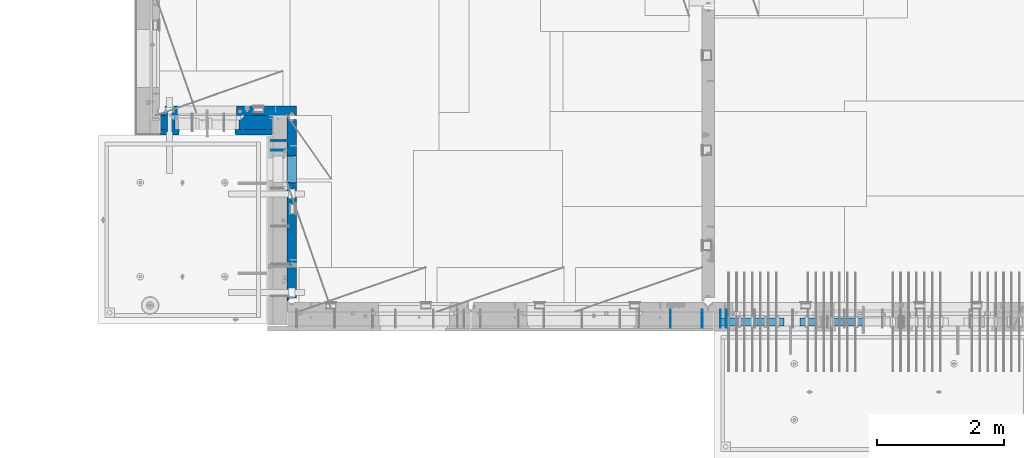
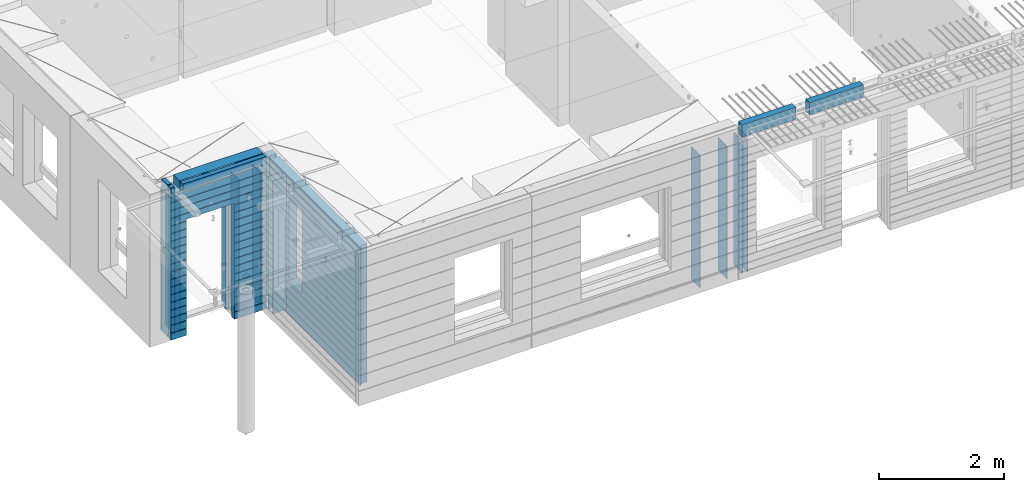
# One storey, part 229 of 350: 16 walls, 7 elements without a shape of their own.
"""IFC2X3 building model written with IfcOpenShell, lengths in millimetres."""

from ifc_helpers import new_model, si_unit, frame, origin_with_axes, place, context, subcontext, project, spatial, faceted_brep, material, type_object, element, aggregate, save


model = new_model("IFC2X3")

# Units and contexts
model_context = context("Model", 3, precision=1e-05, world=origin_with_axes())
body_context = subcontext(model_context, "Body", "Model", "MODEL_VIEW")
ifc_project = project(units=[si_unit("LENGTHUNIT", "METRE", prefix="MILLI"), si_unit("AREAUNIT", "SQUARE_METRE"), si_unit("VOLUMEUNIT", "CUBIC_METRE"), si_unit("MASSUNIT", "GRAM", prefix="KILO"), si_unit("TIMEUNIT", "SECOND"), si_unit("PLANEANGLEUNIT", "RADIAN"), si_unit("SOLIDANGLEUNIT", "STERADIAN"), si_unit("THERMODYNAMICTEMPERATUREUNIT", "DEGREE_CELSIUS"), si_unit("LUMINOUSINTENSITYUNIT", "LUMEN")], contexts=[model_context])

# Site, building, storey
site_placement = place(None, origin_with_axes())
site = spatial("IfcSite", under=ifc_project, at=site_placement, CompositionType="ELEMENT")
building_placement = place(site_placement, origin_with_axes())
building = spatial("IfcBuilding", under=site, at=building_placement, CompositionType="ELEMENT")
storey_placement = place(building_placement, origin_with_axes())
storey = spatial("IfcBuildingStorey", under=building, at=storey_placement, Name="2", CompositionType="ELEMENT", Elevation=0.0)

# Assembly, wall
assembly_1_placement = place(storey_placement, origin_with_axes())
assembly_1 = element("IfcElementAssembly", 1, at=assembly_1_placement, inside=storey, AssemblyPlace="NOTDEFINED", PredefinedType="REINFORCEMENT_UNIT")
ifc_material_1 = material(Name="Undefined")
wall_type_1 = type_object("IfcWallType", PredefinedType="NOTDEFINED")
wall_1_placement = place(assembly_1_placement, frame((16855.0, 7880.0, 86115.0), z_axis=(0.0, 0.0, 1.0), x_axis=(0.0, -1.0, 0.0)))
wall_1 = element("IfcWall", 2, at=wall_1_placement, type_object=wall_type_1, material=ifc_material_1, Name="(PD)", context=body_context, shape_type="Brep", body=[
    faceted_brep([(0.0, 5.0, -1300.0), (0.0, 5.0, 1300.0), (280.0, 5.0, 1300.0), (280.0, 5.0, -1300.0), (0.0, -5.0, 1300.0), (280.0, -5.0, 1300.0), (0.0, -5.0, -1300.0), (280.0, -5.0, -1300.0)], [[[0, 1, 2, 3]], [[1, 4, 5, 2]], [[4, 6, 7, 5]], [[6, 0, 3, 7]], [[5, 7, 3, 2]], [[6, 4, 1, 0]]]),
])

# Assembly, walls
assembly_2_placement = place(storey_placement, origin_with_axes())
assembly_2 = element("IfcElementAssembly", 3, at=assembly_2_placement, inside=storey, AssemblyPlace="NOTDEFINED", PredefinedType="REINFORCEMENT_UNIT")
wall_2_placement = place(assembly_2_placement, frame((16565.0, 7880.0, 86115.0), z_axis=(0.0, 0.0, 1.0), x_axis=(0.0, -1.0, 0.0)))
wall_2 = element("IfcWall", 4, at=wall_2_placement, type_object=wall_type_1, material=ifc_material_1, Name="(PD)", context=body_context, shape_type="Brep", body=[
    faceted_brep([(0.0, 5.0, -1300.0), (0.0, 5.0, 1300.0), (280.0, 5.0, 1300.0), (280.0, 5.0, -1300.0), (0.0, -5.0, 1300.0), (280.0, -5.0, 1300.0), (0.0, -5.0, -1300.0), (280.0, -5.0, -1300.0)], [[[0, 1, 2, 3]], [[1, 4, 5, 2]], [[4, 6, 7, 5]], [[6, 0, 3, 7]], [[5, 7, 3, 2]], [[6, 4, 1, 0]]]),
])
wall_3_placement = place(assembly_2_placement, frame((16065.0, 7880.0, 86115.0), z_axis=(0.0, 0.0, 1.0), x_axis=(0.0, -1.0, 0.0)))
wall_3 = element("IfcWall", 5, at=wall_3_placement, type_object=wall_type_1, material=ifc_material_1, Name="(PD)", context=body_context, shape_type="Brep", body=[
    faceted_brep([(0.0, 5.0, -1300.0), (0.0, 5.0, 1300.0), (280.0, 5.0, 1300.0), (280.0, 5.0, -1300.0), (0.0, -5.0, 1300.0), (280.0, -5.0, 1300.0), (0.0, -5.0, -1300.0), (280.0, -5.0, -1300.0)], [[[0, 1, 2, 3]], [[1, 4, 5, 2]], [[4, 6, 7, 5]], [[6, 0, 3, 7]], [[5, 7, 3, 2]], [[6, 4, 1, 0]]]),
])
aggregate(assembly_2, [wall_2, wall_3])

# Assembly, wall
assembly_3_placement = place(storey_placement, origin_with_axes())
assembly_3 = element("IfcElementAssembly", 6, at=assembly_3_placement, inside=storey, AssemblyPlace="NOTDEFINED", PredefinedType="REINFORCEMENT_UNIT")
wall_4_placement = place(assembly_3_placement, frame((8215.0, 10980.0, 86115.0), z_axis=(0.0, 0.0, 1.0), x_axis=(0.0, -1.0, 0.0)))
wall_4 = element("IfcWall", 7, at=wall_4_placement, type_object=wall_type_1, material=ifc_material_1, Name="(PD)", context=body_context, shape_type="Brep", body=[
    faceted_brep([(0.0, 5.0, -1300.0), (0.0, 5.0, 1300.0), (280.0, 5.0, 1300.0), (280.0, 5.0, -1300.0), (0.0, -5.0, 1300.0), (280.0, -5.0, 1300.0), (0.0, -5.0, -1300.0), (280.0, -5.0, -1300.0)], [[[0, 1, 2, 3]], [[1, 4, 5, 2]], [[4, 6, 7, 5]], [[6, 0, 3, 7]], [[5, 7, 3, 2]], [[6, 4, 1, 0]]]),
])

# Wall
wall_5_placement = place(assembly_1_placement, frame((16945.0, 7880.0, 86115.0), z_axis=(0.0, 0.0, 1.0), x_axis=(0.0, -1.0, 0.0)))
wall_5 = element("IfcWall", 8, at=wall_5_placement, type_object=wall_type_1, material=ifc_material_1, Name="(PD)", context=body_context, shape_type="Brep", body=[
    faceted_brep([(0.0, 5.0, -1300.0), (0.0, 5.0, 1300.0), (280.0, 5.0, 1300.0), (280.0, 5.0, -1300.0), (0.0, -5.0, 1300.0), (280.0, -5.0, 1300.0), (0.0, -5.0, -1300.0), (280.0, -5.0, -1300.0)], [[[0, 1, 2, 3]], [[1, 4, 5, 2]], [[4, 6, 7, 5]], [[6, 0, 3, 7]], [[5, 7, 3, 2]], [[6, 4, 1, 0]]]),
])

aggregate(assembly_1, [wall_1, wall_5])

wall_6_placement = place(assembly_3_placement, frame((8115.0, 10980.0, 86115.0), z_axis=(0.0, 0.0, 1.0), x_axis=(0.0, -1.0, 0.0)))
wall_6 = element("IfcWall", 9, at=wall_6_placement, type_object=wall_type_1, material=ifc_material_1, Name="(PD)", context=body_context, shape_type="Brep", body=[
    faceted_brep([(0.0, 5.0, -1300.0), (0.0, 5.0, 1300.0), (280.0, 5.0, 1300.0), (280.0, 5.0, -1300.0), (0.0, -5.0, 1300.0), (280.0, -5.0, 1300.0), (0.0, -5.0, -1300.0), (280.0, -5.0, -1300.0)], [[[0, 1, 2, 3]], [[1, 4, 5, 2]], [[4, 6, 7, 5]], [[6, 0, 3, 7]], [[5, 7, 3, 2]], [[6, 4, 1, 0]]]),
])

wall_7_placement = place(assembly_3_placement, frame((9315.0, 10980.0, 86115.0), z_axis=(0.0, 0.0, 1.0), x_axis=(0.0, -1.0, 0.0)))
wall_7 = element("IfcWall", 10, at=wall_7_placement, type_object=wall_type_1, material=ifc_material_1, Name="(PD)", context=body_context, shape_type="Brep", body=[
    faceted_brep([(0.0, 5.0, -1300.0), (0.0, 5.0, 1300.0), (280.0, 5.0, 1300.0), (280.0, 5.0, -1300.0), (0.0, -5.0, 1300.0), (280.0, -5.0, 1300.0), (0.0, -5.0, -1300.0), (280.0, -5.0, -1300.0)], [[[0, 1, 2, 3]], [[1, 4, 5, 2]], [[4, 6, 7, 5]], [[6, 0, 3, 7]], [[5, 7, 3, 2]], [[6, 4, 1, 0]]]),
])

wall_8_placement = place(assembly_3_placement, frame((9715.0, 10980.0, 86115.0), z_axis=(0.0, 0.0, 1.0), x_axis=(0.0, -1.0, 0.0)))
wall_8 = element("IfcWall", 11, at=wall_8_placement, type_object=wall_type_1, material=ifc_material_1, Name="(PD)", context=body_context, shape_type="Brep", body=[
    faceted_brep([(0.0, 5.0, -1300.0), (0.0, 5.0, 1300.0), (280.0, 5.0, 1300.0), (280.0, 5.0, -1300.0), (0.0, -5.0, 1300.0), (280.0, -5.0, 1300.0), (0.0, -5.0, -1300.0), (280.0, -5.0, -1300.0)], [[[0, 1, 2, 3]], [[1, 4, 5, 2]], [[4, 6, 7, 5]], [[6, 0, 3, 7]], [[5, 7, 3, 2]], [[6, 4, 1, 0]]]),
])

# Assembly, walls
assembly_4_placement = place(storey_placement, origin_with_axes())
assembly_4 = element("IfcElementAssembly", 12, at=assembly_4_placement, inside=storey, AssemblyPlace="NOTDEFINED", PredefinedType="REINFORCEMENT_UNIT")
wall_9_placement = place(assembly_4_placement, frame((10040.0, 10400.0, 86115.0), z_axis=(0.0, 0.0, 1.0), x_axis=(-1.0, 3.00000001838171e-08, 0.0)))
wall_9 = element("IfcWall", 13, at=wall_9_placement, type_object=wall_type_1, material=ifc_material_1, Name="(PD)", context=body_context, shape_type="Brep", body=[
    faceted_brep([(0.0, 5.0, -1300.0), (0.0, 5.0, 1300.0), (280.0, 5.0, 1300.0), (280.0, 5.0, -1300.0), (0.0, -5.0, 1300.0), (280.0, -5.0, 1300.0), (0.0, -5.0, -1300.0), (280.0, -5.0, -1300.0)], [[[0, 1, 2, 3]], [[1, 4, 5, 2]], [[4, 6, 7, 5]], [[6, 0, 3, 7]], [[5, 7, 3, 2]], [[6, 4, 1, 0]]]),
])
wall_10_placement = place(assembly_4_placement, frame((10040.0, 10550.0, 86115.0), z_axis=(0.0, 0.0, 1.0), x_axis=(-1.0, 3.00000001838171e-08, 0.0)))
wall_10 = element("IfcWall", 14, at=wall_10_placement, type_object=wall_type_1, material=ifc_material_1, Name="(PD)", context=body_context, shape_type="Brep", body=[
    faceted_brep([(0.0, 5.0, -1300.0), (0.0, 5.0, 1300.0), (280.0, 5.0, 1300.0), (280.0, 5.0, -1300.0), (0.0, -5.0, 1300.0), (280.0, -5.0, 1300.0), (0.0, -5.0, -1300.0), (280.0, -5.0, -1300.0)], [[[0, 1, 2, 3]], [[1, 4, 5, 2]], [[4, 6, 7, 5]], [[6, 0, 3, 7]], [[5, 7, 3, 2]], [[6, 4, 1, 0]]]),
])

# Assemblies, walls
assembly_5_placement = place(storey_placement, origin_with_axes())
assembly_5 = element("IfcElementAssembly", 15, at=assembly_5_placement, inside=storey, AssemblyPlace="NOTDEFINED", PredefinedType="REINFORCEMENT_UNIT")
assembly_6_placement = place(assembly_5_placement, origin_with_axes())
assembly_6 = element("IfcElementAssembly", 16, at=assembly_6_placement, Name="Steel Assembly", AssemblyPlace="NOTDEFINED", PredefinedType="NOTDEFINED")
ifc_material_2 = material()
wall_type_2 = type_object("IfcWallType", PredefinedType="NOTDEFINED")
wall_11_placement = place(assembly_6_placement, frame((16859.9998568133, 7690.00021946163, 87590.0), z_axis=(0.0, 0.0, 1.0), x_axis=(1.0, 0.0, 0.0)))
wall_11 = element("IfcWall", 17, at=wall_11_placement, type_object=wall_type_2, material=ifc_material_2, context=body_context, shape_type="Brep", body=[
    faceted_brep([(0.0, 60.0, -120.0), (0.0, 60.0, 120.0), (1000.0, 60.0, 120.0), (1000.0, 60.0, -120.0), (0.0, -60.0, 120.0), (1000.0, -60.0, 120.0), (0.0, -60.0, -120.0), (1000.0, -60.0, -120.0)], [[[0, 1, 2, 3]], [[1, 4, 5, 2]], [[4, 6, 7, 5]], [[6, 0, 3, 7]], [[5, 7, 3, 2]], [[6, 4, 1, 0]]]),
])
aggregate(assembly_6, [wall_11])
assembly_7_placement = place(assembly_5_placement, origin_with_axes())
assembly_7 = element("IfcElementAssembly", 18, at=assembly_7_placement, Name="Steel Assembly", AssemblyPlace="NOTDEFINED", PredefinedType="NOTDEFINED")
aggregate(assembly_5, [assembly_7, assembly_6])
wall_12_placement = place(assembly_7_placement, frame((18109.9998568133, 7690.00021946163, 87590.0), z_axis=(0.0, 0.0, 1.0), x_axis=(1.0, 0.0, 0.0)))
wall_12 = element("IfcWall", 19, at=wall_12_placement, type_object=wall_type_2, material=ifc_material_2, context=body_context, shape_type="Brep", body=[
    faceted_brep([(0.0, 60.0, -120.0), (0.0, 60.0, 120.0), (1000.0, 60.0, 120.0), (1000.0, 60.0, -120.0), (0.0, -60.0, 120.0), (1000.0, -60.0, 120.0), (0.0, -60.0, -120.0), (1000.0, -60.0, -120.0)], [[[0, 1, 2, 3]], [[1, 4, 5, 2]], [[4, 6, 7, 5]], [[6, 0, 3, 7]], [[5, 7, 3, 2]], [[6, 4, 1, 0]]]),
])
aggregate(assembly_7, [wall_12])

# Wall
ifc_material_3 = material(Name="COS5gt")
wall_type_3 = type_object("IfcWallType", PredefinedType="NOTDEFINED")
wall_13_placement = place(assembly_3_placement, frame((9784.0, 10840.0, 86247.5), z_axis=(0.0, 0.0, 1.0), x_axis=(-1.0, 3.00000001838171e-08, 0.0)))
wall_13 = element("IfcWall", 20, at=wall_13_placement, type_object=wall_type_3, material=ifc_material_3, context=body_context, shape_type="Brep", body=[
    faceted_brep([(1699.0, -110.0, 1492.5), (1699.0, 90.0, 1492.5), (1699.0, 90.0, 1442.5), (1699.0, 110.0, 1442.5), (1699.0, 110.0, 1222.5), (1699.0, -110.0, 1222.5), (1549.0, 110.0, 1222.5), (1549.0, -110.0, 1222.5), (1549.0, -110.0, 1492.5), (1549.0, 110.0, 1442.5), (1549.0, 90.0, 1442.5), (1549.0, 90.0, 1492.5), (0.0, -110.0, -1492.5), (0.0, 90.0, -1492.5), (529.001442432404, 90.0, -1492.5), (529.001442432404, -110.0, -1492.5), (0.0, 90.0, -1442.5), (0.0, 110.0, -1442.5), (529.001442432404, 110.0, -1442.5), (529.001442432404, 90.0, -1442.5), (1769.0, 90.0, -1442.5), (1769.0, 90.0, -1492.5), (1539.0014424324, 90.0, -1492.5), (1539.0014424324, 90.0, -1442.5), (1769.0, 110.0, -1442.5), (1539.0014424324, 110.0, -1442.5), (1769.0, 110.0, 1442.5), (1769.0, 90.0, 1442.5), (1769.0, 90.0, 1492.5), (1769.0, -110.0, 1492.5), (1769.0, -110.0, -1492.5), (1539.0014424324, -110.0, -1492.5), (1539.0014424324, -110.0, 847.5), (1539.0014424324, 110.0, 847.5), (529.001442432404, -110.0, 847.5), (529.001442432404, 110.0, 847.5), (0.0, -110.0, 1492.5), (0.0, 90.0, 1492.5), (0.0, 90.0, 1442.5), (0.0, 110.0, 1442.5)], [[[0, 1, 2, 3, 4, 5]], [[5, 4, 6, 7]], [[8, 7, 6, 9, 10, 11]], [[12, 13, 14, 15]], [[16, 17, 18, 19]], [[20, 21, 22, 23]], [[24, 20, 23, 25]], [[26, 27, 28, 29, 30, 21, 20, 24]], [[21, 30, 31, 22]], [[32, 33, 25, 23, 22, 31]], [[34, 35, 33, 32]], [[15, 14, 19, 18, 35, 34]], [[13, 16, 19, 14]], [[13, 12, 36, 37, 38, 39, 17, 16]], [[37, 36, 8, 11]], [[38, 37, 11, 10]], [[39, 38, 10, 9]], [[4, 3, 26, 24, 25, 33, 35, 18, 17, 39, 9, 6]], [[27, 26, 3, 2]], [[28, 27, 2, 1]], [[29, 28, 1, 0]], [[36, 12, 15, 34, 32, 31, 30, 29, 0, 5, 7, 8]]]),
])

ifc_material_4 = material(Name="CONCRETE/C30/37")
wall_type_4 = type_object("IfcWallType", PredefinedType="NOTDEFINED")
wall_14_placement = place(assembly_3_placement, frame((9784.0, 10687.5, 86247.5), z_axis=(0.0, 0.0, 1.0), x_axis=(-1.0, 3.00000001838171e-08, 0.0)))
wall_14 = element("IfcWall", 21, at=wall_14_placement, type_object=wall_type_4, material=ifc_material_4, context=body_context, shape_type="Brep", body=[
    faceted_brep([(1699.0, -42.5, 1492.5), (1699.0, 42.5, 1492.5), (1699.0, 42.5, 1356.99999988925), (1699.0, 32.4999991126988, 1355.00000040044), (1699.0, 32.4999992506928, 1344.99999999921), (1699.0, 42.5, 1342.99999994476), (1699.0, 42.5, 1222.5), (1699.0, -42.5, 1222.5), (1549.0, 42.5, 1222.5), (1549.0, -42.5, 1222.5), (1549.0, -42.5, 1492.5), (1549.0, 42.5, 1342.99999994476), (1549.0, 32.4999992506928, 1344.99999999921), (1549.0, 32.4999991126988, 1355.00000040044), (1549.0, 42.5, 1356.99999988925), (1549.0, 42.5, 1492.5), (1478.99938360887, 42.5, 606.999999889245), (1769.0, 42.5, 606.999999889245), (1769.0, 32.4999991126988, 605.00000040044), (1477.8227168378, 32.4999991126988, 605.00000040044), (1769.0, 32.4999992506928, 594.999999999214), (1477.82271685404, 32.4999992506928, 594.999999999214), (1769.0, 42.5, 592.999999944761), (1478.99938360887, 42.5, 592.999999944761), (1769.0, 42.5, 456.999999889245), (1478.99938360887, 42.5, 456.999999889245), (1769.0, 32.4999991126988, 455.00000040044), (1477.8227168378, 32.4999991126988, 455.00000040044), (1769.0, 32.4999992506928, 444.999999999214), (1477.82271685404, 32.4999992506928, 444.999999999214), (1769.0, 42.5, 442.999999944761), (1478.99938360887, 42.5, 442.999999944761), (1769.0, 42.5, 306.999999889245), (1478.99938360887, 42.5, 306.999999889245), (1769.0, 32.4999991126988, 305.00000040044), (1477.8227168378, 32.4999991126988, 305.00000040044), (1769.0, 32.4999992506928, 294.999999999214), (1477.82271685404, 32.4999992506928, 294.999999999214), (1769.0, 42.5, 292.999999944761), (1478.99938360887, 42.5, 292.999999944761), (1769.0, 42.5, 156.999999889245), (1478.99938360887, 42.5, 156.999999889245), (1769.0, 32.4999991126988, 155.00000040044), (1477.8227168378, 32.4999991126988, 155.00000040044), (1769.0, 32.4999992506928, 144.999999999214), (1477.82271685404, 32.4999992506928, 144.999999999214), (1769.0, 42.5, 142.999999944761), (1478.99938360887, 42.5, 142.999999944761), (1769.0, 42.5, 6.99999988924537), (1478.99938360887, 42.5, 6.99999988924537), (1769.0, 32.4999991126988, 5.0000004004396), (1477.8227168378, 32.4999991126988, 5.0000004004396), (1769.0, 32.4999992506928, -5.0000000007858), (1477.82271685404, 32.4999992506928, -5.0000000007858), (1769.0, 42.5, -7.00000005523907), (1478.99938360887, 42.5, -7.00000005523907), (1769.0, 42.5, -143.000000110755), (1478.99938360887, 42.5, -143.000000110755), (1769.0, 32.4999991126988, -144.99999959956), (1477.8227168378, 32.4999991126988, -144.99999959956), (1769.0, 32.4999992506928, -155.000000000786), (1477.82271685404, 32.4999992506928, -155.000000000786), (1769.0, 42.5, -157.000000055239), (1478.99938360887, 42.5, -157.000000055239), (1769.0, 42.5, -293.000000110755), (1478.99938360887, 42.5, -293.000000110755), (1769.0, 32.4999991126988, -294.99999959956), (1477.8227168378, 32.4999991126988, -294.99999959956), (1769.0, 32.4999992506928, -305.000000000786), (1477.82271685404, 32.4999992506928, -305.000000000786), (1769.0, 42.5, -307.000000055239), (1478.99938360887, 42.5, -307.000000055239), (1769.0, 42.5, -443.000000110755), (1478.99938360887, 42.5, -443.000000110755), (1769.0, 32.4999991126988, -444.99999959956), (1477.8227168378, 32.4999991126988, -444.99999959956), (1769.0, 32.4999992506928, -455.000000000786), (1477.82271685404, 32.4999992506928, -455.000000000786), (1769.0, 42.5, -457.000000055239), (1478.99938360887, 42.5, -457.000000055239), (1769.0, 42.5, -593.000000110755), (1478.99938360887, 42.5, -593.000000110755), (1769.0, 32.4999991126988, -594.99999959956), (1477.8227168378, 32.4999991126988, -594.99999959956), (1769.0, 32.4999992506928, -605.000000000786), (1477.82271685404, 32.4999992506928, -605.000000000786), (1769.0, 42.5, -607.000000055239), (1478.99938360887, 42.5, -607.000000055239), (1769.0, 42.5, -743.000000110755), (1478.99938360887, 42.5, -743.000000110755), (1769.0, 32.4999991126988, -744.99999959956), (1477.8227168378, 32.4999991126988, -744.99999959956), (1769.0, 32.4999992506928, -755.000000000786), (1477.82271685404, 32.4999992506928, -755.000000000786), (1769.0, 42.5, -757.000000055239), (1478.99938360887, 42.5, -757.000000055239), (1769.0, 42.5, -893.000000110755), (1478.99938360887, 42.5, -893.000000110755), (1769.0, 32.4999991126988, -894.99999959956), (1477.8227168378, 32.4999991126988, -894.99999959956), (1769.0, 32.4999992506928, -905.000000000786), (1477.82271685404, 32.4999992506928, -905.000000000786), (1769.0, 42.5, -907.000000055239), (1478.99938360887, 42.5, -907.000000055239), (1769.0, 42.5, -1043.00000011075), (1478.99938360887, 42.5, -1043.00000011075), (1769.0, 32.4999991126988, -1044.99999959956), (1477.8227168378, 32.4999991126988, -1044.99999959956), (1769.0, 32.4999992506928, -1055.00000000079), (1477.82271685404, 32.4999992506928, -1055.00000000079), (1769.0, 42.5, -1057.00000005524), (1478.99938360887, 42.5, -1057.00000005524), (1769.0, 42.5, -1193.00000011075), (1478.99938360887, 42.5, -1193.00000011075), (1769.0, 32.4999991126988, -1194.99999959956), (1477.8227168378, 32.4999991126988, -1194.99999959956), (1769.0, 32.4999992506928, -1205.00000000079), (1477.82271685404, 32.4999992506928, -1205.00000000079), (1769.0, 42.5, -1207.00000005524), (1478.99938360887, 42.5, -1207.00000005524), (1769.0, 42.5, -1343.00000011075), (1478.99938360887, 42.5, -1343.00000011075), (1769.0, 32.4999991126988, -1344.99999959956), (1477.8227168378, 32.4999991126988, -1344.99999959956), (1769.0, 32.4999992506928, -1355.00000000079), (1477.82271685404, 32.4999992506928, -1355.00000000079), (1769.0, 42.5, -1357.00000005524), (1478.99938360887, 42.5, -1357.00000005524), (1769.0, 42.5, -1492.5), (1478.99938360887, 42.5, -1492.5), (1769.0, -42.5, -1492.5), (1468.99771694221, -42.5, -1492.5), (599.001442432404, 42.5, 782.5), (1469.0014424324, 42.5, 782.5), (1478.99938360887, 42.5, 782.5), (1468.99771694221, -42.5, 787.502857142856), (599.001050275541, -42.5, 787.502857142856), (588.999383608874, 42.5, 782.5), (1478.99938360887, 42.5, 742.999999944761), (1468.99771694221, -42.5, 782.5), (1478.99938360887, 42.5, 756.999999889245), (1477.82271683781, 32.4999991126988, 755.00000040044), (1477.82271685404, 32.4999992506928, 744.999999999214), (1769.0, 42.5, 742.999999944761), (1769.0, 32.4999992506928, 744.999999999214), (1769.0, 32.4999991126988, 755.00000040044), (1769.0, 42.5, 756.999999889245), (0.0, 32.4999991127006, 905.00000040044), (1769.0, 32.4999991126988, 905.00000040044), (1769.0, 32.4999992506928, 894.999999999214), (0.0, 32.4999992507037, 894.999999999258), (0.0, 42.5, 906.999999889245), (1769.0, 42.5, 906.999999889245), (0.0, 42.5, 1042.99999994476), (1769.0, 42.5, 1042.99999994476), (0.0, 32.4999992507037, 1044.99999999926), (1769.0, 32.4999992506928, 1044.99999999921), (0.0, 32.4999991127006, 1055.00000040044), (1769.0, 32.4999991126988, 1055.00000040044), (0.0, 42.5, 1056.99999988925), (1769.0, 42.5, 1056.99999988925), (0.0, 42.5, 1192.99999994476), (1769.0, 42.5, 1192.99999994476), (0.0, 32.4999992507037, 1194.99999999926), (1769.0, 32.4999992506928, 1194.99999999921), (0.0, 32.4999991127006, 1205.00000040044), (1769.0, 32.4999991126988, 1205.00000040044), (0.0, 42.5, 1206.99999988925), (1769.0, 42.5, 1206.99999988925), (1769.0, 42.5, 1492.5), (1769.0, -42.5, 1492.5), (1769.0, 42.5, 892.999999944761), (1769.0, 42.5, 1342.99999994476), (1769.0, 32.4999992506928, 1344.99999999921), (1769.0, 32.4999991126988, 1355.00000040044), (1769.0, 42.5, 1356.99999988925), (0.0, 42.5, 892.999999944761), (588.999383608874, 42.5, 756.999999889245), (0.0, 42.5, 756.999999889245), (588.999383608874, 42.5, -1492.5), (0.0, 42.5, -1492.5), (0.0, 42.5, -1357.00000005524), (588.999383608874, 42.5, -1357.00000005524), (0.0, 32.4999992507037, -1355.00000000074), (590.176050363707, 32.4999992506928, -1355.00000000079), (0.0, 32.4999991127006, -1344.99999959956), (590.176050379945, 32.4999991126988, -1344.99999959956), (0.0, 42.5, -1343.00000011075), (588.999383608874, 42.5, -1343.00000011075), (0.0, 42.5, -1207.00000005524), (588.999383608874, 42.5, -1207.00000005524), (0.0, 32.4999992507037, -1205.00000000074), (590.176050363709, 32.4999992506928, -1205.00000000079), (0.0, 32.4999991127006, -1194.99999959956), (590.176050379947, 32.4999991126988, -1194.99999959956), (0.0, 42.5, -1193.00000011075), (588.999383608874, 42.5, -1193.00000011075), (0.0, 42.5, -1057.00000005524), (588.999383608874, 42.5, -1057.00000005524), (0.0, 32.4999992507037, -1055.00000000074), (590.176050363711, 32.4999992506928, -1055.00000000079), (0.0, 32.4999991127006, -1044.99999959956), (590.176050379947, 32.4999991126988, -1044.99999959956), (0.0, 42.5, -1043.00000011075), (588.999383608874, 42.5, -1043.00000011075), (0.0, 42.5, -907.000000055239), (588.999383608874, 42.5, -907.000000055239), (0.0, 32.4999992507037, -905.000000000742), (590.176050363711, 32.4999992506928, -905.000000000786), (0.0, 32.4999991127006, -894.99999959956), (590.176050379947, 32.4999991126988, -894.99999959956), (0.0, 42.5, -893.000000110755), (588.999383608874, 42.5, -893.000000110755), (0.0, 42.5, -757.000000055239), (588.999383608874, 42.5, -757.000000055239), (0.0, 32.4999992507037, -755.000000000742), (590.176050363711, 32.4999992506928, -755.000000000786), (0.0, 32.4999991127006, -744.99999959956), (590.176050379947, 32.4999991126988, -744.99999959956), (0.0, 42.5, -743.000000110755), (588.999383608874, 42.5, -743.000000110755), (0.0, 42.5, -607.000000055239), (588.999383608874, 42.5, -607.000000055239), (3.63797880709171e-12, 32.4999992507037, -605.000000000742), (590.176050363709, 32.4999992506928, -605.000000000786), (3.63797880709171e-12, 32.4999991127006, -594.99999959956), (590.176050379947, 32.4999991126988, -594.99999959956), (0.0, 42.5, -593.000000110755), (588.999383608874, 42.5, -593.000000110755), (0.0, 42.5, -457.000000055239), (588.999383608874, 42.5, -457.000000055239), (0.0, 32.4999992507037, -455.000000000742), (590.176050363711, 32.4999992506928, -455.000000000786), (0.0, 32.4999991127006, -444.99999959956), (590.176050379947, 32.4999991126988, -444.99999959956), (0.0, 42.5, -443.000000110755), (588.999383608874, 42.5, -443.000000110755), (0.0, 42.5, -307.000000055239), (588.999383608874, 42.5, -307.000000055239), (0.0, 32.4999992507037, -305.000000000742), (590.176050363711, 32.4999992506928, -305.000000000786), (0.0, 32.4999991127006, -294.99999959956), (590.176050379947, 32.4999991126988, -294.99999959956), (0.0, 42.5, -293.000000110755), (588.999383608874, 42.5, -293.000000110755), (0.0, 42.5, -157.000000055239), (588.999383608874, 42.5, -157.000000055239), (3.63797880709171e-12, 32.4999992507037, -155.000000000742), (590.176050363707, 32.4999992506928, -155.000000000786), (3.63797880709171e-12, 32.4999991127006, -144.99999959956), (590.176050379945, 32.4999991126988, -144.99999959956), (0.0, 42.5, -143.000000110755), (588.999383608874, 42.5, -143.000000110755), (0.0, 42.5, -7.00000005523907), (588.999383608874, 42.5, -7.00000005523907), (0.0, 32.4999992507037, -5.00000000074215), (590.176050363705, 32.4999992506928, -5.0000000007858), (0.0, 32.4999991127006, 5.0000004004396), (590.176050379941, 32.4999991126988, 5.0000004004396), (0.0, 42.5, 6.99999988924537), (588.999383608874, 42.5, 6.99999988924537), (0.0, 42.5, 142.999999944761), (588.999383608874, 42.5, 142.999999944761), (-3.63797880709171e-12, 32.4999992507037, 144.999999999258), (590.176050363705, 32.4999992506928, 144.999999999214), (-3.63797880709171e-12, 32.4999991127006, 155.00000040044), (590.176050379943, 32.4999991126988, 155.00000040044), (0.0, 42.5, 156.999999889245), (588.999383608874, 42.5, 156.999999889245), (0.0, 42.5, 292.999999944761), (588.999383608874, 42.5, 292.999999944761), (-3.63797880709171e-12, 32.4999992507037, 294.999999999258), (590.176050363703, 32.4999992506928, 294.999999999214), (-3.63797880709171e-12, 32.4999991127006, 305.00000040044), (590.17605037994, 32.4999991126988, 305.00000040044), (0.0, 42.5, 306.999999889245), (588.999383608874, 42.5, 306.999999889245), (0.0, 42.5, 442.999999944761), (588.999383608874, 42.5, 442.999999944761), (0.0, 32.4999992507037, 444.999999999258), (590.176050363702, 32.4999992506928, 444.999999999214), (0.0, 32.4999991127006, 455.00000040044), (590.176050379938, 32.4999991126988, 455.00000040044), (0.0, 42.5, 456.999999889245), (588.999383608874, 42.5, 456.999999889245), (0.0, 42.5, 592.999999944761), (588.999383608874, 42.5, 592.999999944761), (3.63797880709171e-12, 32.4999992507037, 594.999999999258), (590.176050363702, 32.4999992506928, 594.999999999214), (3.63797880709171e-12, 32.4999991127006, 605.00000040044), (590.17605037994, 32.4999991126988, 605.00000040044), (0.0, 42.5, 606.999999889245), (588.999383608874, 42.5, 606.999999889245), (0.0, 42.5, 742.999999944761), (588.999383608874, 42.5, 742.999999944761), (0.0, 32.4999992507037, 744.999999999258), (590.176050363705, 32.4999992506928, 744.999999999214), (0.0, 32.4999991127006, 755.00000040044), (590.176050379943, 32.4999991126988, 755.00000040044), (599.001050275541, -42.5, 782.5), (599.001050275539, -42.5, -1492.5), (0.0, -42.5, -1492.5), (-3.63797880709171e-12, 32.4999992507037, 1344.99999999926), (0.0, 42.5, 1342.99999994476), (0.0, -42.5, 1492.5), (0.0, 42.5, 1492.5), (0.0, 42.5, 1356.99999988925), (-3.63797880709171e-12, 32.4999991127006, 1355.00000040044)], [[[0, 1, 2, 3, 4, 5, 6, 7]], [[7, 6, 8, 9]], [[10, 9, 8, 11, 12, 13, 14, 15]], [[16, 17, 18, 19]], [[19, 18, 20, 21]], [[21, 20, 22, 23]], [[24, 25, 23, 22]], [[25, 24, 26, 27]], [[27, 26, 28, 29]], [[29, 28, 30, 31]], [[32, 33, 31, 30]], [[33, 32, 34, 35]], [[35, 34, 36, 37]], [[37, 36, 38, 39]], [[40, 41, 39, 38]], [[41, 40, 42, 43]], [[43, 42, 44, 45]], [[45, 44, 46, 47]], [[48, 49, 47, 46]], [[49, 48, 50, 51]], [[51, 50, 52, 53]], [[53, 52, 54, 55]], [[56, 57, 55, 54]], [[57, 56, 58, 59]], [[59, 58, 60, 61]], [[61, 60, 62, 63]], [[64, 65, 63, 62]], [[65, 64, 66, 67]], [[67, 66, 68, 69]], [[69, 68, 70, 71]], [[72, 73, 71, 70]], [[73, 72, 74, 75]], [[75, 74, 76, 77]], [[77, 76, 78, 79]], [[80, 81, 79, 78]], [[81, 80, 82, 83]], [[83, 82, 84, 85]], [[85, 84, 86, 87]], [[88, 89, 87, 86]], [[89, 88, 90, 91]], [[91, 90, 92, 93]], [[93, 92, 94, 95]], [[96, 97, 95, 94]], [[97, 96, 98, 99]], [[99, 98, 100, 101]], [[101, 100, 102, 103]], [[104, 105, 103, 102]], [[105, 104, 106, 107]], [[107, 106, 108, 109]], [[109, 108, 110, 111]], [[112, 113, 111, 110]], [[113, 112, 114, 115]], [[115, 114, 116, 117]], [[117, 116, 118, 119]], [[120, 121, 119, 118]], [[121, 120, 122, 123]], [[123, 122, 124, 125]], [[125, 124, 126, 127]], [[128, 129, 127, 126]], [[128, 130, 131, 129]], [[132, 133, 134, 135, 136, 137]], [[138, 16, 19, 21, 23, 25, 27, 29, 31, 33, 35, 37, 39, 41, 43, 45, 47, 49, 51, 53, 55, 57, 59, 61, 63, 65, 67, 69, 71, 73, 75, 77, 79, 81, 83, 85, 87, 89, 91, 93, 95, 97, 99, 101, 103, 105, 107, 109, 111, 113, 115, 117, 119, 121, 123, 125, 127, 129, 131, 139, 135, 134, 140, 141, 142]], [[17, 16, 138, 143]], [[142, 144, 143, 138]], [[141, 145, 144, 142]], [[140, 146, 145, 141]], [[147, 148, 149, 150]], [[151, 152, 148, 147]], [[152, 151, 153, 154]], [[155, 156, 154, 153]], [[157, 158, 156, 155]], [[159, 160, 158, 157]], [[160, 159, 161, 162]], [[163, 164, 162, 161]], [[165, 166, 164, 163]], [[167, 168, 166, 165]], [[169, 170, 130, 128, 126, 124, 122, 120, 118, 116, 114, 112, 110, 108, 106, 104, 102, 100, 98, 96, 94, 92, 90, 88, 86, 84, 82, 80, 78, 76, 74, 72, 70, 68, 66, 64, 62, 60, 58, 56, 54, 52, 50, 48, 46, 44, 42, 40, 38, 36, 34, 32, 30, 28, 26, 24, 22, 20, 18, 17, 143, 144, 145, 146, 171, 149, 148, 152, 154, 156, 158, 160, 162, 164, 166, 168, 172, 173, 174, 175]], [[150, 149, 171, 176]], [[146, 140, 134, 133, 132, 137, 177, 178, 176, 171]], [[179, 180, 181, 182]], [[183, 184, 182, 181]], [[185, 186, 184, 183]], [[187, 188, 186, 185]], [[188, 187, 189, 190]], [[191, 192, 190, 189]], [[193, 194, 192, 191]], [[195, 196, 194, 193]], [[196, 195, 197, 198]], [[199, 200, 198, 197]], [[201, 202, 200, 199]], [[203, 204, 202, 201]], [[204, 203, 205, 206]], [[207, 208, 206, 205]], [[209, 210, 208, 207]], [[211, 212, 210, 209]], [[212, 211, 213, 214]], [[215, 216, 214, 213]], [[217, 218, 216, 215]], [[219, 220, 218, 217]], [[220, 219, 221, 222]], [[223, 224, 222, 221]], [[225, 226, 224, 223]], [[227, 228, 226, 225]], [[228, 227, 229, 230]], [[231, 232, 230, 229]], [[233, 234, 232, 231]], [[235, 236, 234, 233]], [[236, 235, 237, 238]], [[239, 240, 238, 237]], [[241, 242, 240, 239]], [[243, 244, 242, 241]], [[244, 243, 245, 246]], [[247, 248, 246, 245]], [[249, 250, 248, 247]], [[251, 252, 250, 249]], [[252, 251, 253, 254]], [[255, 256, 254, 253]], [[257, 258, 256, 255]], [[259, 260, 258, 257]], [[260, 259, 261, 262]], [[263, 264, 262, 261]], [[265, 266, 264, 263]], [[267, 268, 266, 265]], [[268, 267, 269, 270]], [[271, 272, 270, 269]], [[273, 274, 272, 271]], [[275, 276, 274, 273]], [[276, 275, 277, 278]], [[279, 280, 278, 277]], [[281, 282, 280, 279]], [[283, 284, 282, 281]], [[284, 283, 285, 286]], [[287, 288, 286, 285]], [[289, 290, 288, 287]], [[291, 292, 290, 289]], [[292, 291, 293, 294]], [[295, 296, 294, 293]], [[297, 298, 296, 295]], [[178, 177, 298, 297]], [[137, 136, 299, 300, 179, 182, 184, 186, 188, 190, 192, 194, 196, 198, 200, 202, 204, 206, 208, 210, 212, 214, 216, 218, 220, 222, 224, 226, 228, 230, 232, 234, 236, 238, 240, 242, 244, 246, 248, 250, 252, 254, 256, 258, 260, 262, 264, 266, 268, 270, 272, 274, 276, 278, 280, 282, 284, 286, 288, 290, 292, 294, 296, 298, 177]], [[301, 180, 179, 300]], [[302, 303, 167, 165, 163, 161, 159, 157, 155, 153, 151, 147, 150, 176, 178, 297, 295, 293, 291, 289, 287, 285, 283, 281, 279, 277, 275, 273, 271, 269, 267, 265, 263, 261, 259, 257, 255, 253, 251, 249, 247, 245, 243, 241, 239, 237, 235, 233, 231, 229, 227, 225, 223, 221, 219, 217, 215, 213, 211, 209, 207, 205, 203, 201, 199, 197, 195, 193, 191, 189, 187, 185, 183, 181, 180, 301, 304, 305, 306, 307]], [[305, 304, 10, 15]], [[306, 305, 15, 14]], [[307, 306, 14, 13]], [[302, 307, 13, 12]], [[303, 302, 12, 11]], [[6, 5, 172, 168, 167, 303, 11, 8]], [[173, 172, 5, 4]], [[174, 173, 4, 3]], [[175, 174, 3, 2]], [[169, 175, 2, 1]], [[170, 169, 1, 0]], [[304, 301, 300, 299, 136, 135, 139, 131, 130, 170, 0, 7, 9, 10]]]),
])

ifc_material_5 = material(Name="CONCRETE/C25/30")
wall_type_5 = type_object("IfcWallType", PredefinedType="NOTDEFINED")
wall_15_placement = place(assembly_3_placement, frame((10160.0, 11025.0, 86112.5), z_axis=(0.0, 0.0, 1.0), x_axis=(-1.0, 3.00000001838171e-08, 0.0)))
wall_15 = element("IfcWall", 22, at=wall_15_placement, type_object=wall_type_5, material=ifc_material_5, context=body_context, shape_type="Brep", body=[
    faceted_brep([(47.9999996848892, 54.9999994175323, 1357.5), (47.9999996848892, 54.9999994175323, -1357.5), (34.999999998452, 55.0000022791301, -1357.5), (34.999999998452, 55.0000022791301, 1357.5), (24.999999998452, 75.0000022791301, 1357.5), (24.999999998452, 75.0, -1357.5), (124.999999998452, 75.0, 1357.5), (124.999999998452, 75.0, -1357.5), (114.999999998452, 55.0000022791301, -1357.5), (114.999999998452, 55.0000022791301, 1357.5), (101.99999958942, 54.999999390373, 1357.5), (101.99999958942, 54.999999390373, -1357.5), (945.001442432404, -75.0, -1357.5), (949.055496486459, 75.0, -1357.5), (949.055496486457, 75.0, 948.445945945947), (945.001442432404, -75.0, 952.5), (0.0, -75.0, -1357.5), (0.0, 75.0, -1357.5), (2145.0, 75.0, 1357.5), (2145.0, 75.0, -1357.5), (1870.94738837835, 75.0, -1357.5), (1870.94738837835, 75.0, 948.445945945947), (2145.0, 45.0, 1357.5), (2145.0, 45.0, -1357.5), (2074.9999995581, 32.0, 1357.5), (2074.9999995581, 32.0, -1357.5), (2074.9999995581, -75.0, 1357.5), (2074.9999995581, -75.0, -1357.5), (1875.0014424324, -75.0, -1357.5), (1875.0014424324, -75.0, 952.5), (0.0, -75.0, 1357.5), (0.0, 75.0, 1357.5)], [[[0, 1, 2, 3]], [[4, 3, 2, 5]], [[6, 7, 8, 9]], [[10, 9, 8, 11]], [[10, 11, 1, 0]], [[12, 13, 14, 15]], [[1, 11, 8, 7, 13, 12, 16, 17, 5, 2]], [[18, 19, 20, 21, 14, 13, 7, 6]], [[19, 18, 22, 23]], [[24, 25, 23, 22]], [[26, 27, 25, 24]], [[19, 23, 25, 27, 28, 20]], [[20, 28, 29, 21]], [[15, 14, 21, 29]], [[28, 27, 26, 30, 16, 12, 15, 29]], [[16, 30, 31, 17]], [[17, 31, 4, 5]], [[31, 30, 26, 24, 22, 18, 6, 9, 10, 0, 3, 4]]]),
])

aggregate(assembly_3, [wall_4, wall_6, wall_7, wall_8, wall_14, wall_13, wall_15])

wall_16_placement = place(assembly_4_placement, frame((10085.0, 8000.0, 86112.5), z_axis=(0.0, 0.0, 1.0), x_axis=(0.0, 1.0, 0.0)))
wall_16 = element("IfcWall", 23, at=wall_16_placement, type_object=wall_type_5, material=ifc_material_5, context=body_context, shape_type="Brep", body=[
    faceted_brep([(2934.99999772087, 40.0, 1357.5), (2934.99999772087, 75.0, 1357.5), (15.0, 75.0, 1357.5), (15.0, 65.0, 1357.5), (65.0, 35.0, 1357.5), (65.0, -75.0, 1357.5), (2885.0, -75.0, 1357.5), (2885.0, 27.0, 1357.5), (15.0, 75.0, -1357.5), (15.0, 65.0, -1357.5), (65.0, 35.0, -1357.5), (65.0, -75.0, -1357.5), (2885.0, -75.0, -1357.5), (1885.00042424099, -75.0000000030959, -682.5), (1885.00042424099, -75.0000000030959, 952.5), (2315.00042424099, -75.0000000030959, 952.5), (2315.00042424099, -75.0000000030959, -682.5), (2885.0, 27.0, -1357.5), (2934.99999772087, 75.0, -1357.5), (2934.99999772087, 40.0, -1357.5), (1889.05447829513, 75.0, -678.445945945859), (2310.94637018685, 75.0, -678.445945945859), (2310.94637018685, 75.0, 948.445945945859), (1889.05447829513, 75.0, 948.445945945859)], [[[0, 1, 2, 3, 4, 5, 6, 7]], [[2, 8, 9, 3]], [[3, 9, 10, 4]], [[5, 4, 10, 11]], [[5, 11, 12, 6], [13, 14, 15, 16]], [[6, 12, 17, 7]], [[11, 10, 9, 8, 18, 19, 17, 12]], [[7, 17, 19, 0]], [[18, 1, 0, 19]], [[8, 2, 1, 18], [20, 21, 22, 23]], [[15, 22, 21, 16]], [[14, 23, 22, 15]], [[13, 20, 23, 14]], [[16, 21, 20, 13]]]),
])

aggregate(assembly_4, [wall_9, wall_10, wall_16])

save(model, "model.ifc")
